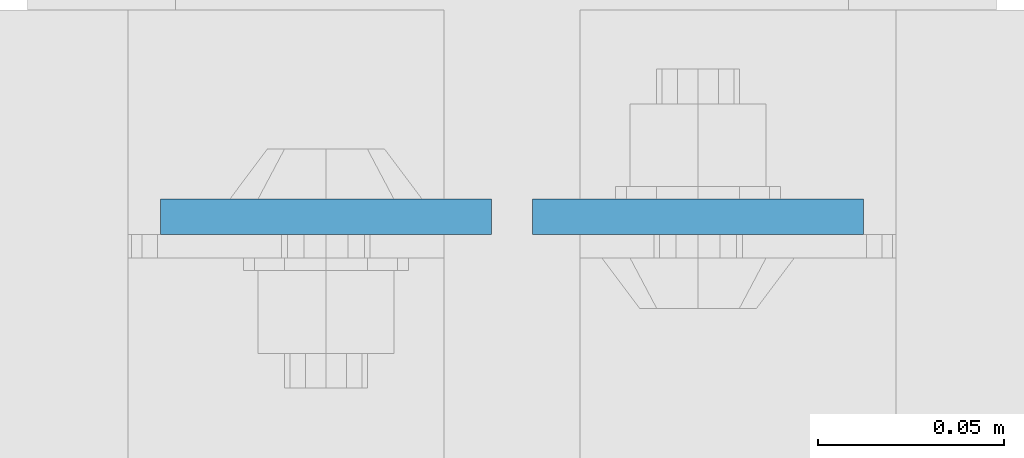
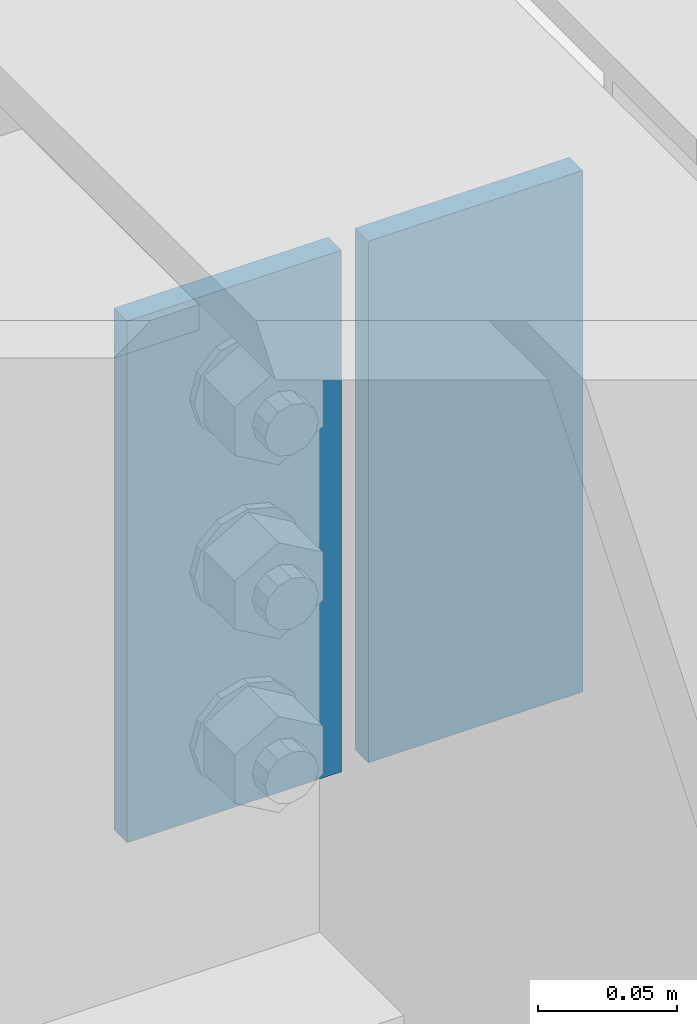
# One storey, part 3169 of 3843: 2 plates, 1 element without a shape of its own.
"""IFC2X3 building model written with IfcOpenShell, lengths in millimetres."""

from ifc_helpers import new_model, si_unit, frame, origin_with_axes, place, context, subcontext, project, spatial, faceted_brep, material, type_object, element, aggregate, save


model = new_model("IFC2X3")

# Units and contexts
model_context = context("Model", 3, precision=1e-05, world=origin_with_axes())
body_context = subcontext(model_context, "Body", "Model", "MODEL_VIEW")
ifc_project = project(units=[si_unit("LENGTHUNIT", "METRE", prefix="MILLI"), si_unit("AREAUNIT", "SQUARE_METRE"), si_unit("VOLUMEUNIT", "CUBIC_METRE"), si_unit("MASSUNIT", "GRAM", prefix="KILO"), si_unit("TIMEUNIT", "SECOND"), si_unit("PLANEANGLEUNIT", "RADIAN"), si_unit("SOLIDANGLEUNIT", "STERADIAN"), si_unit("THERMODYNAMICTEMPERATUREUNIT", "DEGREE_CELSIUS"), si_unit("LUMINOUSINTENSITYUNIT", "LUMEN")], contexts=[model_context])

# Site, building, storey
site_placement = place(None, origin_with_axes())
site = spatial("IfcSite", under=ifc_project, at=site_placement, CompositionType="ELEMENT")
building_placement = place(site_placement, origin_with_axes())
building = spatial("IfcBuilding", under=site, at=building_placement, Name="Undefined", CompositionType="ELEMENT")
storey_placement = place(building_placement, origin_with_axes())
storey = spatial("IfcBuildingStorey", under=building, at=storey_placement, Name="Undefined", CompositionType="ELEMENT", Elevation=0.0)

# Assembly, plates
assembly_placement = place(storey_placement, origin_with_axes())
assembly = element("IfcElementAssembly", 1, at=assembly_placement, inside=storey, Name="BEAM", AssemblyPlace="NOTDEFINED", PredefinedType="RIGID_FRAME")
ifc_material = material(Name="STEEL/A572-50")
plate_type = type_object("IfcPlateType", PredefinedType="NOTDEFINED")
plate_1_placement = place(assembly_placement, frame((62641.95625, 19253.5175, 42418.0), z_axis=(1.0, 0.0, 0.0), x_axis=(0.0, 0.0, -1.0)))
plate_1 = element("IfcPlate", 2, at=plate_1_placement, type_object=plate_type, material=ifc_material, Name="PLATE", context=body_context, shape_type="Brep", body=[
    faceted_brep([(0.0, -4.76249999999709, 0.0), (0.0, -4.76249999999709, 88.9000015258789), (0.0, 4.76249999999709, 88.9000015258789), (0.0, 4.76249999999709, 0.0), (228.600006102781, -4.7625000004191, 88.9000015257589), (228.600006102781, 4.76249999954598, 88.9000015257443), (228.600006103079, -4.7625000004482, 7.27595761418343e-12), (228.600006103079, 4.76249999954598, -7.27595761418343e-12)], [[[0, 1, 2, 3]], [[1, 4, 5, 2]], [[4, 6, 7, 5]], [[6, 0, 3, 7]], [[5, 7, 3, 2]], [[6, 4, 1, 0]]]),
])
plate_2_placement = place(assembly_placement, frame((62630.84375, 19253.5175, 42418.0), z_axis=(-1.0, 0.0, 0.0), x_axis=(0.0, 0.0, -1.0)))
plate_2 = element("IfcPlate", 3, at=plate_2_placement, type_object=plate_type, material=ifc_material, Name="PLATE", context=body_context, shape_type="Brep", body=[
    faceted_brep([(0.0, -4.76249999999709, 0.0), (0.0, -4.76249999999709, 88.9000015258789), (0.0, 4.76249999999709, 88.9000015258789), (0.0, 4.76249999999709, 0.0), (228.600006102781, -4.7625000004191, 88.9000015257589), (228.600006102781, 4.76249999954598, 88.9000015257443), (228.600006103079, -4.7625000004482, 7.27595761418343e-12), (228.600006103079, 4.76249999954598, -7.27595761418343e-12)], [[[0, 1, 2, 3]], [[1, 4, 5, 2]], [[4, 6, 7, 5]], [[6, 0, 3, 7]], [[5, 7, 3, 2]], [[6, 4, 1, 0]]]),
])
aggregate(assembly, [plate_1, plate_2])

save(model, "model.ifc")
